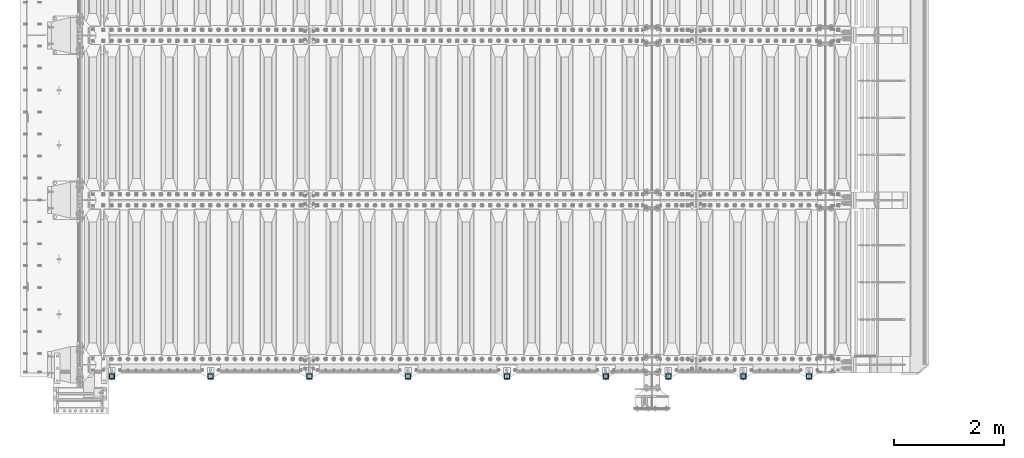
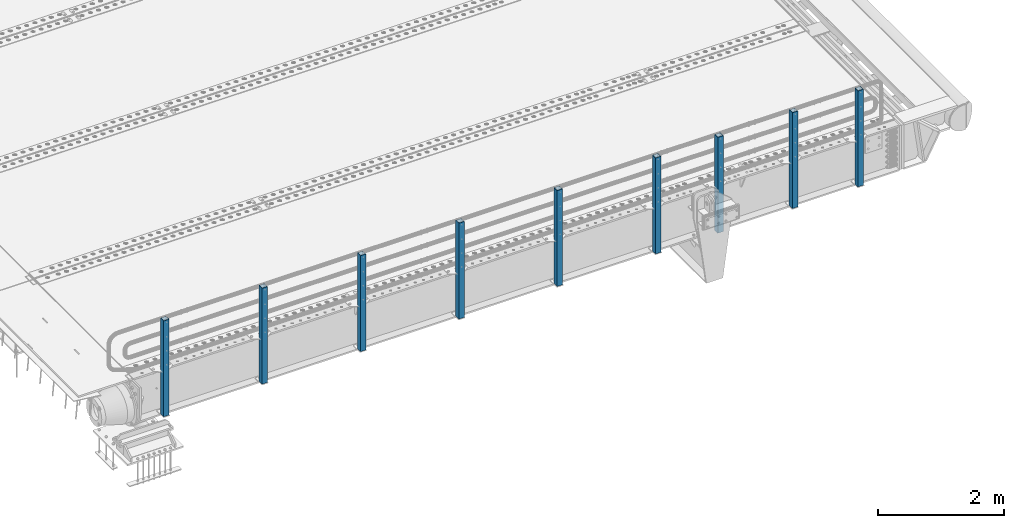
# One storey, part 62 of 240: 9 columns.
"""IFC2X3 building model written with IfcOpenShell, lengths in millimetres."""

from ifc_helpers import new_model, si_unit, frame, origin_with_axes, place, context, subcontext, project, spatial, faceted_brep, material, type_object, element, save


model = new_model("IFC2X3")

# Units and contexts
model_context = context("Model", 3, precision=1e-05, world=origin_with_axes())
body_context = subcontext(model_context, "Body", "Model", "MODEL_VIEW")
ifc_project = project(units=[si_unit("LENGTHUNIT", "METRE", prefix="MILLI"), si_unit("AREAUNIT", "SQUARE_METRE"), si_unit("VOLUMEUNIT", "CUBIC_METRE"), si_unit("MASSUNIT", "GRAM", prefix="KILO"), si_unit("TIMEUNIT", "SECOND"), si_unit("PLANEANGLEUNIT", "RADIAN"), si_unit("SOLIDANGLEUNIT", "STERADIAN"), si_unit("THERMODYNAMICTEMPERATUREUNIT", "DEGREE_CELSIUS"), si_unit("LUMINOUSINTENSITYUNIT", "LUMEN")], contexts=[model_context])

# Site, building, storey
site_placement = place(None, origin_with_axes())
site = spatial("IfcSite", under=ifc_project, at=site_placement, CompositionType="ELEMENT")
building_placement = place(site_placement, origin_with_axes())
building = spatial("IfcBuilding", under=site, at=building_placement, Name="Standard", CompositionType="ELEMENT")
storey_placement = place(building_placement, origin_with_axes())
storey = spatial("IfcBuildingStorey", under=building, at=storey_placement, Name="Undefined", CompositionType="ELEMENT", Elevation=0.0)

# Columns
ifc_material = material()
column_type = type_object("IfcColumnType", PredefinedType="NOTDEFINED")
for number, where, z_axis, x_axis in (
    (1, (55704.9999999999, 23789.9999999998, -844.999999999998), (0.0, 1.0, 0.0), (0.0, 0.0, 1.0)),
    (2, (54504.9999999999, 23789.9999999998, -844.999999999998), (0.0, 1.0, 0.0), (0.0, 0.0, 1.0)),
    (3, (53139.9999999999, 23789.9999999998, -844.999999999998), (0.0, 1.0, 0.0), (0.0, 0.0, 1.0)),
    (4, (51999.9999999999, 23789.9999999998, -844.999999999998), (0.0, 1.0, 0.0), (0.0, 0.0, 1.0)),
    (5, (50199.9999999999, 23789.9999999998, -844.999999999998), (0.0, 1.0, 0.0), (0.0, 0.0, 1.0)),
    (6, (48399.9999999999, 23789.9999999998, -844.999999999998), (0.0, 1.0, 0.0), (0.0, 0.0, 1.0)),
    (7, (46599.9999999999, 23789.9999999998, -844.999999999998), (0.0, 1.0, 0.0), (0.0, 0.0, 1.0)),
    (8, (44799.9999999999, 23789.9999999998, -844.999999999998), (0.0, 1.0, 0.0), (0.0, 0.0, 1.0)),
    (9, (42999.9999999999, 23789.9999999998, -844.999999999998), (0.0, 1.0, 0.0), (0.0, 0.0, 1.0)),
):
    element("IfcColumn", number, at=place(storey_placement, frame(where, z_axis=z_axis, x_axis=x_axis)), inside=storey, type_object=column_type, material=ifc_material, context=body_context, shape_type="Brep", body=[
        faceted_brep([(0.0, 40.0, -40.0), (0.0, -40.0, -40.0), (1855.0, -40.0, -40.0), (1855.0, 40.0, -40.0), (0.0, -40.0, 40.0), (1855.0, -40.0, 40.0), (0.0, 40.0, 40.0), (1855.0, 40.0, 40.0), (0.0, 50.0, -50.0), (0.0, 50.0, 50.0), (1855.0, 50.0, 50.0), (1855.0, 50.0, -50.0), (0.0, -50.0, 50.0), (1855.0, -50.0, 50.0), (0.0, -50.0, -50.0), (1855.0, -50.0, -50.0)], [[[0, 1, 2, 3]], [[1, 4, 5, 2]], [[4, 6, 7, 5]], [[6, 0, 3, 7]], [[8, 9, 10, 11]], [[9, 12, 13, 10]], [[12, 14, 15, 13]], [[14, 8, 11, 15]], [[13, 15, 11, 10], [5, 7, 3, 2]], [[14, 12, 9, 8], [6, 4, 1, 0]]]),
    ])

save(model, "model.ifc")
